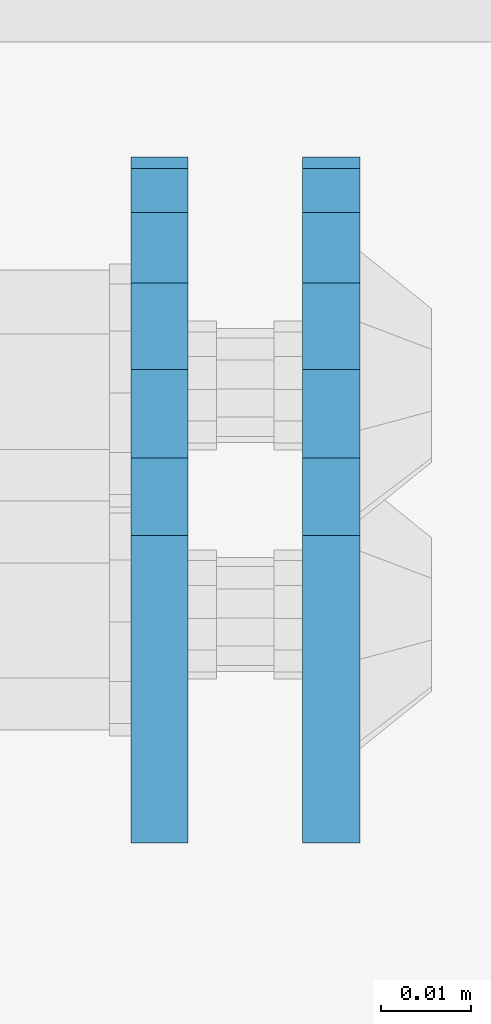
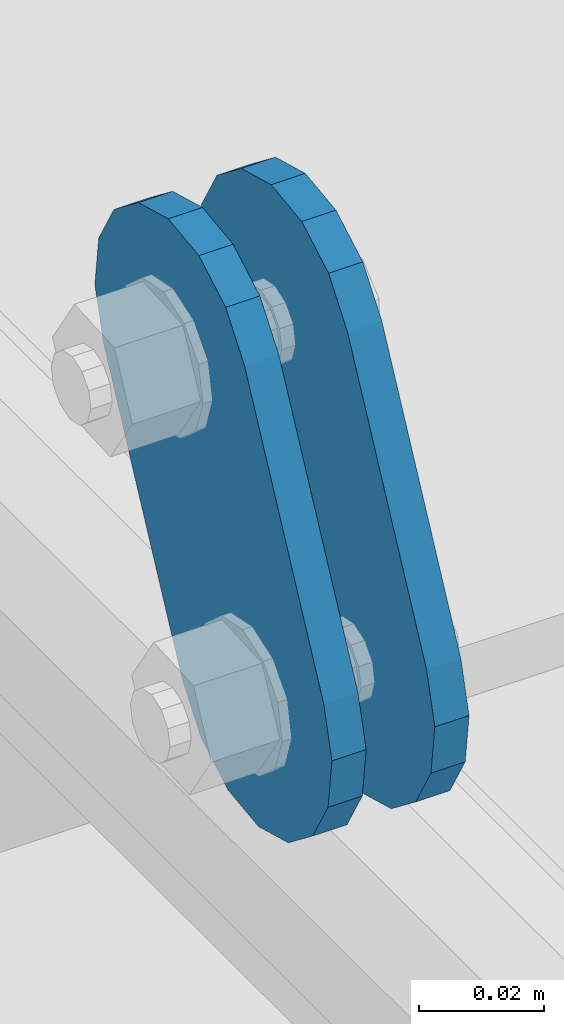
# One storey, part 1444 of 1876: 2 plates, 2 elements without a shape of their own.
"""IFC2X3 building model written with IfcOpenShell, lengths in millimetres."""

from ifc_helpers import new_model, si_unit, frame, origin_with_axes, place, context, subcontext, project, spatial, faceted_brep, material, type_object, element, aggregate, save


model = new_model("IFC2X3")

# Units and contexts
model_context = context("Model", 3, precision=1e-05, world=origin_with_axes())
body_context = subcontext(model_context, "Body", "Model", "MODEL_VIEW")
ifc_project = project(units=[si_unit("LENGTHUNIT", "METRE", prefix="MILLI"), si_unit("AREAUNIT", "SQUARE_METRE"), si_unit("VOLUMEUNIT", "CUBIC_METRE"), si_unit("MASSUNIT", "GRAM", prefix="KILO"), si_unit("TIMEUNIT", "SECOND"), si_unit("PLANEANGLEUNIT", "RADIAN"), si_unit("SOLIDANGLEUNIT", "STERADIAN"), si_unit("THERMODYNAMICTEMPERATUREUNIT", "DEGREE_CELSIUS"), si_unit("LUMINOUSINTENSITYUNIT", "LUMEN")], contexts=[model_context])

# Site, building, storey
site_placement = place(None, origin_with_axes())
site = spatial("IfcSite", under=ifc_project, at=site_placement, CompositionType="ELEMENT")
building_placement = place(site_placement, origin_with_axes())
building = spatial("IfcBuilding", under=site, at=building_placement, Name="Undefined", CompositionType="ELEMENT")
storey_placement = place(building_placement, origin_with_axes())
storey = spatial("IfcBuildingStorey", under=building, at=storey_placement, Name="Undefined", CompositionType="ELEMENT", Elevation=0.0)

# Assembly, plate
assembly_1_placement = place(storey_placement, origin_with_axes())
assembly_1 = element("IfcElementAssembly", 1, at=assembly_1_placement, inside=storey, Name="PLATE", AssemblyPlace="NOTDEFINED", PredefinedType="RIGID_FRAME")
ifc_material = material(Name="STEEL/A36")
plate_type = type_object("IfcPlateType", PredefinedType="NOTDEFINED")
plate_1_placement = place(assembly_1_placement, frame((5086.35, -7466.25922341129, 7895.37767748094), z_axis=(0.0, 0.894427191199917, -0.447213595099955), x_axis=(0.0, -0.447213595099955, -0.894427191199917)))
plate_1 = element("IfcPlate", 2, at=plate_1_placement, type_object=plate_type, material=ifc_material, Name="PLATE", context=body_context, shape_type="Brep", body=[
    faceted_brep([(-8.59611645864788e-07, -3.17499999999654, 25.3999987589127), (1.93345873884391, -3.17499999999382, 35.1201580589886), (1.93345873884391, 3.17500000000564, 35.1201580589886), (-8.59611645864788e-07, 3.17500000000382, 25.3999987589132), (7.43948648259902, -3.17499999999109, 43.3605112870105), (7.43948648259902, 3.17500000000928, 43.3605112870105), (15.6798395242777, -3.17499999998654, 48.8665393096448), (15.6798395242777, 3.17500000001382, 48.8665393096448), (25.3999987589095, -3.17499999998199, 50.7999992370592), (25.3999987589095, 3.17500000001837, 50.7999992370592), (82.196130752618, -3.17499999998381, 50.7999992370605), (82.196130752618, 3.17500000001655, 50.7999992370642), (91.9162897887145, -3.17499999997926, 48.8665393918873), (91.9162897887145, 3.1750000000211, 48.8665393918909), (100.156642725027, -3.17499999997472, 43.3605115909359), (100.156642725027, 3.17500000002565, 43.3605115909395), (105.662670525982, -3.17499999997108, 35.1201586546285), (105.662670525986, 3.17500000002929, 35.1201586546358), (107.596130371159, -3.17499999996744, 25.3999996185757), (107.596130371159, 3.17500000003292, 25.3999996185794), (105.662670525981, -3.17499999996471, 15.6798405824902), (105.662670525981, 3.17500000003565, 15.6798405824939), (100.156642725024, -3.17499999996471, 7.43948764618654), (100.156642725025, 3.17500000003565, 7.43948764619017), (91.9162897887127, -3.17499999996562, 1.93345984522784), (91.9162897887127, 3.17500000003474, 1.93345984523148), (82.196130752618, -3.17499999996835, 4.54747350886464e-11), (82.196130752618, 3.1750000000311, 4.91127138957381e-11), (25.399998758905, -3.17499999999018, -8.64019966684282e-12), (25.399998758905, 3.17500000001019, -8.64019966684282e-12), (15.679839921364, -3.17499999999382, 1.9334597629304), (15.679839921364, 3.17500000000655, 1.9334597629304), (7.43948709043525, -3.17499999999654, 7.43948734220839), (7.43948709043525, 3.17500000000382, 7.43948734220885), (1.93345923228208, -3.17499999999654, 15.6798399868012), (1.93345923228208, 3.17500000000291, 15.6798399868012)], [[[0, 1, 2, 3]], [[1, 4, 5, 2]], [[4, 6, 7, 5]], [[6, 8, 9, 7]], [[8, 10, 11, 9]], [[10, 12, 13, 11]], [[12, 14, 15, 13]], [[14, 16, 17, 15]], [[16, 18, 19, 17]], [[18, 20, 21, 19]], [[20, 22, 23, 21]], [[22, 24, 25, 23]], [[24, 26, 27, 25]], [[26, 28, 29, 27]], [[28, 30, 31, 29]], [[30, 32, 33, 31]], [[32, 34, 35, 33]], [[34, 0, 3, 35]], [[5, 7, 9, 11, 13, 15, 17, 19, 21, 23, 25, 27, 29, 31, 33, 35, 3, 2]], [[34, 32, 30, 28, 26, 24, 22, 20, 18, 16, 14, 12, 10, 8, 6, 4, 1, 0]]]),
])
aggregate(assembly_1, [plate_1])

assembly_2_placement = place(storey_placement, origin_with_axes())
assembly_2 = element("IfcElementAssembly", 3, at=assembly_2_placement, inside=storey, Name="PLATE", AssemblyPlace="NOTDEFINED", PredefinedType="RIGID_FRAME")
plate_2_placement = place(assembly_2_placement, frame((5067.28879521564, -7466.25922341129, 7895.37767748094), z_axis=(0.0, 0.894427191199917, -0.447213595099955), x_axis=(0.0, -0.447213595099955, -0.894427191199917)))
plate_2 = element("IfcPlate", 4, at=plate_2_placement, type_object=plate_type, material=ifc_material, Name="PLATE", context=body_context, shape_type="Brep", body=[
    faceted_brep([(-8.59611645864788e-07, -3.17499999999654, 25.3999987589127), (1.93345873884391, -3.17499999999382, 35.1201580589886), (1.93345873884391, 3.17500000000564, 35.1201580589886), (-8.59611645864788e-07, 3.17500000000382, 25.3999987589132), (7.43948648259902, -3.17499999999109, 43.3605112870105), (7.43948648259902, 3.17500000000928, 43.3605112870105), (15.6798395242777, -3.17499999998654, 48.8665393096448), (15.6798395242777, 3.17500000001382, 48.8665393096448), (25.3999987589095, -3.17499999998199, 50.7999992370592), (25.3999987589095, 3.17500000001837, 50.7999992370592), (82.196130752618, -3.17499999998381, 50.7999992370605), (82.196130752618, 3.17500000001655, 50.7999992370642), (91.9162897887145, -3.17499999997926, 48.8665393918873), (91.9162897887145, 3.1750000000211, 48.8665393918909), (100.156642725027, -3.17499999997472, 43.3605115909359), (100.156642725027, 3.17500000002565, 43.3605115909395), (105.662670525982, -3.17499999997108, 35.1201586546285), (105.662670525986, 3.17500000002929, 35.1201586546358), (107.596130371159, -3.17499999996744, 25.3999996185757), (107.596130371159, 3.17500000003292, 25.3999996185794), (105.662670525981, -3.17499999996471, 15.6798405824902), (105.662670525981, 3.17500000003565, 15.6798405824939), (100.156642725024, -3.17499999996471, 7.43948764618654), (100.156642725025, 3.17500000003565, 7.43948764619017), (91.9162897887127, -3.17499999996562, 1.93345984522784), (91.9162897887127, 3.17500000003474, 1.93345984523148), (82.196130752618, -3.17499999996835, 4.54747350886464e-11), (82.196130752618, 3.1750000000311, 4.91127138957381e-11), (25.399998758905, -3.17499999999018, -8.64019966684282e-12), (25.399998758905, 3.17500000001019, -8.64019966684282e-12), (15.679839921364, -3.17499999999382, 1.9334597629304), (15.679839921364, 3.17500000000655, 1.9334597629304), (7.43948709043525, -3.17499999999654, 7.43948734220839), (7.43948709043525, 3.17500000000382, 7.43948734220885), (1.93345923228208, -3.17499999999654, 15.6798399868012), (1.93345923228208, 3.17500000000291, 15.6798399868012)], [[[0, 1, 2, 3]], [[1, 4, 5, 2]], [[4, 6, 7, 5]], [[6, 8, 9, 7]], [[8, 10, 11, 9]], [[10, 12, 13, 11]], [[12, 14, 15, 13]], [[14, 16, 17, 15]], [[16, 18, 19, 17]], [[18, 20, 21, 19]], [[20, 22, 23, 21]], [[22, 24, 25, 23]], [[24, 26, 27, 25]], [[26, 28, 29, 27]], [[28, 30, 31, 29]], [[30, 32, 33, 31]], [[32, 34, 35, 33]], [[34, 0, 3, 35]], [[5, 7, 9, 11, 13, 15, 17, 19, 21, 23, 25, 27, 29, 31, 33, 35, 3, 2]], [[34, 32, 30, 28, 26, 24, 22, 20, 18, 16, 14, 12, 10, 8, 6, 4, 1, 0]]]),
])
aggregate(assembly_2, [plate_2])

save(model, "model.ifc")
